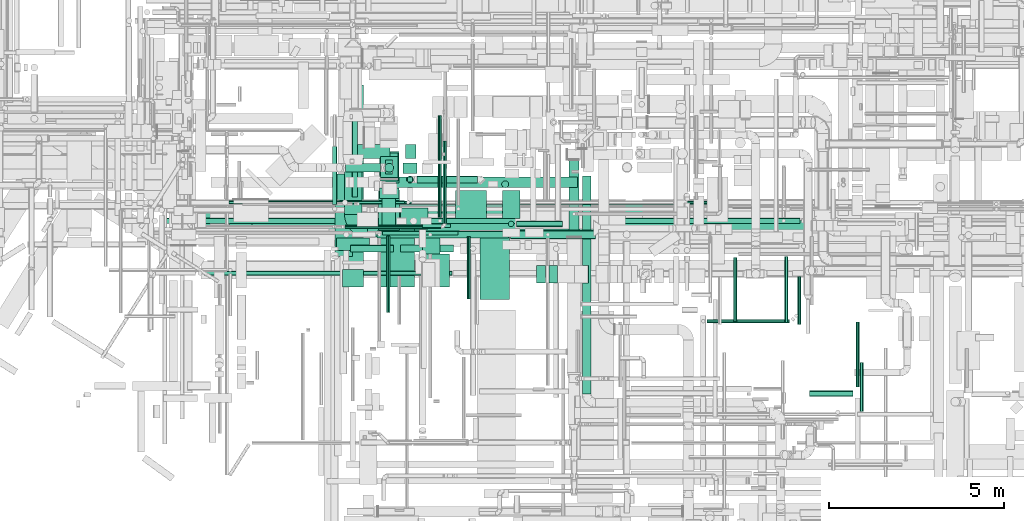
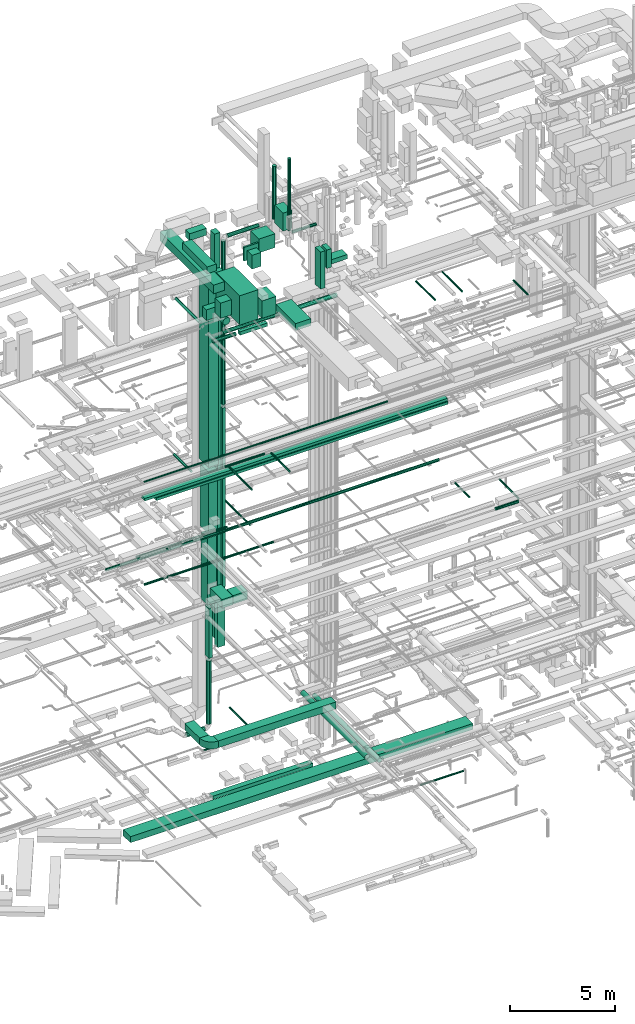
# One storey, part 31 of 337: 64 flow segments, 1 flow fitting.
"""IFC2X3 building model written with IfcOpenShell, lengths in millimetres."""

from ifc_helpers import new_model, entity, si_unit, converted_unit, derived_unit, direction, frame, frame_2d, origin, origin_2d_with_axis, place, context, subcontext, project, spatial, polyline, circle_curve, parameter, trimmed, segment, composite_curve, rectangle, circle, outline, extrude, source, transform, mapped, material, type_object, type_shapes, element, save


model = new_model("IFC2X3")

# Units and contexts
model_context = context("Model", 3, precision=0.01, world=origin(), true_north=direction((6.12303176911189e-17, 1.0)))
body_context = subcontext(model_context, "Body", "Model", "MODEL_VIEW")
ifc_project = project(units=[si_unit("LENGTHUNIT", "METRE", prefix="MILLI"), si_unit("AREAUNIT", "SQUARE_METRE"), si_unit("VOLUMEUNIT", "CUBIC_METRE"), converted_unit("PLANEANGLEUNIT", "DEGREE", entity("IfcRatioMeasure", 0.0174532925199433), si_unit("PLANEANGLEUNIT", "RADIAN"), dimensions=[0, 0, 0, 0, 0, 0, 0]), si_unit("MASSUNIT", "GRAM", prefix="KILO"), derived_unit("MASSDENSITYUNIT", [(si_unit("MASSUNIT", "GRAM", prefix="KILO"), 1), (si_unit("LENGTHUNIT", "METRE"), -3)]), derived_unit("MOMENTOFINERTIAUNIT", [(si_unit("LENGTHUNIT", "METRE"), 4)]), si_unit("TIMEUNIT", "SECOND"), si_unit("FREQUENCYUNIT", "HERTZ"), si_unit("THERMODYNAMICTEMPERATUREUNIT", "DEGREE_CELSIUS"), derived_unit("THERMALTRANSMITTANCEUNIT", [(si_unit("MASSUNIT", "GRAM", prefix="KILO"), 1), (si_unit("THERMODYNAMICTEMPERATUREUNIT", "KELVIN"), -1), (si_unit("TIMEUNIT", "SECOND"), -3)]), derived_unit("VOLUMETRICFLOWRATEUNIT", [(si_unit("LENGTHUNIT", "METRE"), 3), (si_unit("TIMEUNIT", "SECOND"), -1)]), derived_unit("MASSFLOWRATEUNIT", [(si_unit("MASSUNIT", "GRAM", prefix="KILO"), 1), (si_unit("TIMEUNIT", "SECOND"), -1)]), derived_unit("ROTATIONALFREQUENCYUNIT", [(si_unit("TIMEUNIT", "SECOND"), -1)]), si_unit("ELECTRICCURRENTUNIT", "AMPERE"), si_unit("ELECTRICVOLTAGEUNIT", "VOLT"), si_unit("POWERUNIT", "WATT"), si_unit("FORCEUNIT", "NEWTON", prefix="KILO"), si_unit("ILLUMINANCEUNIT", "LUX"), si_unit("LUMINOUSFLUXUNIT", "LUMEN"), si_unit("LUMINOUSINTENSITYUNIT", "CANDELA"), derived_unit("USERDEFINED", [(si_unit("MASSUNIT", "GRAM", prefix="KILO"), -1), (si_unit("LENGTHUNIT", "METRE"), -2), (si_unit("TIMEUNIT", "SECOND"), 3), (si_unit("LUMINOUSFLUXUNIT", "LUMEN"), 1)]), derived_unit("LINEARVELOCITYUNIT", [(si_unit("LENGTHUNIT", "METRE"), 1), (si_unit("TIMEUNIT", "SECOND"), -1)]), si_unit("PRESSUREUNIT", "PASCAL"), derived_unit("USERDEFINED", [(si_unit("LENGTHUNIT", "METRE"), -2), (si_unit("MASSUNIT", "GRAM", prefix="KILO"), 1), (si_unit("TIMEUNIT", "SECOND"), -2)]), derived_unit("LINEARFORCEUNIT", [(si_unit("MASSUNIT", "GRAM", prefix="KILO"), 1), (si_unit("LENGTHUNIT", "METRE"), 1), (si_unit("TIMEUNIT", "SECOND"), -2), (si_unit("LENGTHUNIT", "METRE"), -1)]), derived_unit("PLANARFORCEUNIT", [(si_unit("MASSUNIT", "GRAM", prefix="KILO"), 1), (si_unit("LENGTHUNIT", "METRE"), 1), (si_unit("TIMEUNIT", "SECOND"), -2), (si_unit("LENGTHUNIT", "METRE"), -2)])], contexts=[model_context])

# Site, building, storey
site_placement = place(None, origin())
site = spatial("IfcSite", under=ifc_project, at=site_placement, CompositionType="ELEMENT")
building_placement = place(site_placement, origin())
building = spatial("IfcBuilding", under=site, at=building_placement, CompositionType="ELEMENT")
storey_placement = place(building_placement, origin())
storey = spatial("IfcBuildingStorey", under=building, at=storey_placement, CompositionType="ELEMENT", Elevation=0.0)

# Flow segments
duct_segment_type_1 = type_object("IfcDuctSegmentType", PredefinedType="NOTDEFINED")
flow_segment_1_placement = place(storey_placement, frame((19019.38, 9470.01, -800.0)))
element("IfcFlowSegment", 1, at=flow_segment_1_placement, inside=storey, type_object=duct_segment_type_1, context=body_context, shape_type="SweptSolid", body=[
    extrude(rectangle(XDim=18790.1284833971, YDim=700.0, at=origin_2d_with_axis()), frame((9395.06, 350.0, 0.0)), (0.0, 0.0, 1.0), 350.0),
])
flow_segment_2_placement = place(storey_placement, frame((24662.3, 9490.54, 11050.0)))
element("IfcFlowSegment", 2, at=flow_segment_2_placement, inside=storey, type_object=duct_segment_type_1, context=body_context, shape_type="SweptSolid", body=[
    extrude(rectangle(XDim=795.000000000274, YDim=600.000000000001, at=origin_2d_with_axis()), frame((397.5, 300.0, 0.0), z_axis=(0.0, 0.0, 1.0), x_axis=(-1.0, 0.0, 0.0)), (0.0, 0.0, 1.0), 499.999999999999),
])
flow_segment_3_placement = place(storey_placement, frame((23065.55, 9899.08, 3200.0)))
element("IfcFlowSegment", 3, at=flow_segment_3_placement, inside=storey, type_object=duct_segment_type_1, context=body_context, shape_type="SweptSolid", body=[
    extrude(rectangle(XDim=1412.49999999996, YDim=499.999999999999, at=origin_2d_with_axis()), frame((250.0, 706.25, 0.0), z_axis=(0.0, 0.0, 1.0), x_axis=(0.0, 1.0, 0.0)), (0.0, 0.0, 1.0), 400.0),
])
flow_segment_4_placement = place(storey_placement, frame((23715.55, 9249.08, 3200.0)))
element("IfcFlowSegment", 4, at=flow_segment_4_placement, inside=storey, type_object=duct_segment_type_1, context=body_context, shape_type="SweptSolid", body=[
    extrude(rectangle(XDim=6460.00000000001, YDim=500.0, at=origin_2d_with_axis()), frame((3230.0, 250.0, 0.0)), (0.0, 0.0, 1.0), 400.0),
])
flow_segment_5_placement = place(storey_placement, frame((24092.29, 10849.36, 14489.99)))
element("IfcFlowSegment", 5, at=flow_segment_5_placement, inside=storey, type_object=duct_segment_type_1, context=body_context, shape_type="SweptSolid", body=[
    extrude(rectangle(XDim=499.999999999992, YDim=800.0, at=origin_2d_with_axis()), frame((250.0, 400.0, 0.01), z_axis=(3.9000782821359e-05, 0.0, 1.0), x_axis=(-1.0, 0.0, 3.9000782821359e-05)), (0.0, 0.0, 1.0), 3600.00000056566),
])
flow_segment_6_placement = place(storey_placement, frame((24242.3, 11049.36, 7100.0)))
element("IfcFlowSegment", 6, at=flow_segment_6_placement, inside=storey, type_object=duct_segment_type_1, context=body_context, shape_type="SweptSolid", body=[
    extrude(rectangle(XDim=400.0, YDim=199.999999999998, at=origin_2d_with_axis()), frame((100.0, 200.0, 0.0), z_axis=(0.0, 0.0, 1.0), x_axis=(0.0, 1.0, 0.0)), (0.0, 0.0, 1.0), 2910.00000000006),
])
flow_segment_7_placement = place(storey_placement, frame((24092.3, 10949.36, 10310.0)))
element("IfcFlowSegment", 7, at=flow_segment_7_placement, inside=storey, type_object=duct_segment_type_1, context=body_context, shape_type="SweptSolid", body=[
    extrude(rectangle(XDim=499.999999999999, YDim=600.0, at=origin_2d_with_axis()), frame((250.0, 300.0, 0.0), z_axis=(0.0, 0.0, 1.0), x_axis=(-1.0, 0.0, 0.0)), (0.0, 0.0, 1.0), 3880.00000000004),
])
flow_segment_8_placement = place(storey_placement, frame((24067.42, 10799.36, 18390.0)))
element("IfcFlowSegment", 8, at=flow_segment_8_placement, inside=storey, type_object=duct_segment_type_1, context=body_context, shape_type="SweptSolid", body=[
    extrude(rectangle(XDim=900.000000000001, YDim=549.999999999999, at=origin_2d_with_axis()), frame((275.01, 450.0, 0.0), z_axis=(-1.06206758286217e-06, 0.0, 1.0), x_axis=(0.0, 1.0, 0.0)), (0.0, 0.0, 1.0), 10469.9999552325),
])
flow_segment_9_placement = place(storey_placement, frame((19781.36, 9425.09, 18780.0)))
element("IfcFlowSegment", 9, at=flow_segment_9_placement, inside=storey, type_object=duct_segment_type_1, context=body_context, shape_type="SweptSolid", body=[
    extrude(rectangle(XDim=16609.7802616782, YDim=300.0, at=origin_2d_with_axis()), frame((8304.89, 150.0, 0.0), z_axis=(0.0, 0.0, 1.0), x_axis=(-1.0, 0.0, 0.0)), (0.0, 0.0, 1.0), 150.000000000001),
])
flow_segment_10_placement = place(storey_placement, frame((24042.3, 9460.54, 11050.0)))
element("IfcFlowSegment", 10, at=flow_segment_10_placement, inside=storey, type_object=duct_segment_type_1, context=body_context, shape_type="SweptSolid", body=[
    extrude(rectangle(XDim=1137.81651873405, YDim=600.000000000002, at=origin_2d_with_axis()), frame((300.0, 568.91, 0.0), z_axis=(0.0, 0.0, 1.0), x_axis=(0.0, 1.0, 0.0)), (0.0, 0.0, 1.0), 499.999999999999),
])
flow_segment_11_placement = place(storey_placement, frame((20420.04, 9425.61, 18580.0)))
element("IfcFlowSegment", 11, at=flow_segment_11_placement, inside=storey, type_object=duct_segment_type_1, context=body_context, shape_type="SweptSolid", body=[
    extrude(rectangle(XDim=16005.2921321211, YDim=300.0, at=origin_2d_with_axis()), frame((8002.65, 150.0, 0.0)), (0.0, 0.0, 1.0), 150.000000000001),
])
flow_segment_12_placement = place(storey_placement, frame((24671.92, 8824.98, 27050.0)))
element("IfcFlowSegment", 12, at=flow_segment_12_placement, inside=storey, type_object=duct_segment_type_1, context=body_context, shape_type="SweptSolid", body=[
    extrude(rectangle(XDim=1504.99999999992, YDim=200.0, at=origin_2d_with_axis()), frame((752.5, 100.0, 0.0), z_axis=(0.0, 0.0, 1.0), x_axis=(-1.0, 0.0, 0.0)), (0.0, 0.0, 1.0), 199.999999999998),
])
flow_segment_13_placement = place(storey_placement, frame((24808.28, 11498.95, 7800.0)))
element("IfcFlowSegment", 13, at=flow_segment_13_placement, inside=storey, type_object=duct_segment_type_1, context=body_context, shape_type="SweptSolid", body=[
    extrude(rectangle(XDim=300.000000000001, YDim=400.0, at=origin_2d_with_axis()), frame((150.0, 200.0, 0.0)), (0.0, 0.0, 1.0), 23450.0000000001),
])
flow_segment_14_placement = place(storey_placement, frame((24733.23, 11074.99, 7550.0)))
element("IfcFlowSegment", 14, at=flow_segment_14_placement, inside=storey, type_object=duct_segment_type_1, context=body_context, shape_type="SweptSolid", body=[
    extrude(rectangle(XDim=300.000000000001, YDim=400.0, at=origin_2d_with_axis()), frame((200.0, 150.0, 0.0), z_axis=(0.0, 0.0, 1.0), x_axis=(0.0, -1.0, 0.0)), (0.0, 0.0, 1.0), 20899.9997394166),
])
flow_segment_15_placement = place(storey_placement, frame((26930.62, 7474.06, 27350.0)))
element("IfcFlowSegment", 15, at=flow_segment_15_placement, inside=storey, type_object=duct_segment_type_1, context=body_context, shape_type="SweptSolid", body=[
    extrude(rectangle(XDim=1865.90580735633, YDim=850.000000000002, at=origin_2d_with_axis()), frame((425.0, 932.95, 0.0), z_axis=(0.0, 0.0, 1.0), x_axis=(0.0, 1.0, 0.0)), (0.0, 0.0, 1.0), 399.999999999996),
])
flow_segment_16_placement = place(storey_placement, frame((22842.03, 8872.6, 28512.0)))
element("IfcFlowSegment", 16, at=flow_segment_16_placement, inside=storey, type_object=duct_segment_type_1, context=body_context, shape_type="SweptSolid", body=[
    extrude(rectangle(XDim=357.000000000056, YDim=939.999999999999, at=origin_2d_with_axis()), frame((470.0, 178.5, 0.0), z_axis=(0.0, 0.0, 1.0), x_axis=(0.0, -1.0, 0.0)), (0.0, 0.0, 1.0), 619.999999999998),
])
flow_segment_17_placement = place(storey_placement, frame((24861.21, 10822.55, 11150.0)))
element("IfcFlowSegment", 17, at=flow_segment_17_placement, inside=storey, type_object=duct_segment_type_1, context=body_context, shape_type="SweptSolid", body=[
    extrude(rectangle(XDim=150.000000000001, YDim=150.000000000001, at=origin_2d_with_axis()), frame((75.0, 75.0, 0.0), z_axis=(0.0, 0.0, 1.0), x_axis=(0.0, 1.0, 0.0)), (0.0, 0.0, 1.0), 10392.0),
])
flow_segment_18_placement = place(storey_placement, frame((24231.5, 10670.0, -850.0)))
element("IfcFlowSegment", 18, at=flow_segment_18_placement, inside=storey, type_object=duct_segment_type_1, context=body_context, shape_type="SweptSolid", body=[
    extrude(rectangle(XDim=5495.94816144537, YDim=299.999999999999, at=origin_2d_with_axis()), frame((2747.97, 150.0, 0.0), z_axis=(0.0, 0.0, 1.0), x_axis=(-1.0, 0.0, 0.0)), (0.0, 0.0, 1.0), 200.0),
])
duct_segment_type_2 = type_object("IfcDuctSegmentType", PredefinedType="NOTDEFINED")
flow_segment_19_placement = place(storey_placement, frame((33418.35, 6797.92, -951.6)))
element("IfcFlowSegment", 19, at=flow_segment_19_placement, inside=storey, type_object=duct_segment_type_2, context=body_context, shape_type="SweptSolid", body=[
    extrude(circle(Radius=50.0, at=origin_2d_with_axis()), frame((0.0, 51.6, 51.6), z_axis=(1.0, 0.0, 0.0), x_axis=(0.0, -1.0, 0.0)), (0.0, 0.0, 1.0), 2362.95263376269),
])
flow_segment_20_placement = place(storey_placement, frame((23095.67, 11107.76, 2843.4)))
element("IfcFlowSegment", 20, at=flow_segment_20_placement, inside=storey, type_object=duct_segment_type_2, context=body_context, shape_type="SweptSolid", body=[
    extrude(circle(Radius=125.0, at=origin_2d_with_axis()), frame((0.0, 126.6, 126.6), z_axis=(1.0, 0.0, 0.0), x_axis=(0.0, -1.0, 0.0)), (0.0, 0.0, 1.0), 996.624916994883),
])
flow_segment_21_placement = place(storey_placement, frame((23084.87, 9491.98, 3048.4)))
element("IfcFlowSegment", 21, at=flow_segment_21_placement, inside=storey, type_object=duct_segment_type_2, context=body_context, shape_type="SweptSolid", body=[
    extrude(circle(Radius=50.0, at=origin_2d_with_axis()), frame((0.0, 51.6, 51.6), z_axis=(1.0, 0.0, 0.0), x_axis=(0.0, 1.0, 0.0)), (0.0, 0.0, 1.0), 2738.57864376277),
])
flow_segment_22_placement = place(storey_placement, frame((25871.85, 9643.58, 3048.4)))
element("IfcFlowSegment", 22, at=flow_segment_22_placement, inside=storey, type_object=duct_segment_type_2, context=body_context, shape_type="SweptSolid", body=[
    extrude(circle(Radius=50.0, at=origin_2d_with_axis()), frame((51.6, 0.0, 51.6), z_axis=(0.0, 1.0, 0.0), x_axis=(1.0, 0.0, 0.0)), (0.0, 0.0, 1.0), 2359.99999999999),
])
flow_segment_23_placement = place(storey_placement, frame((29864.42, 4770.47, 2873.4)))
element("IfcFlowSegment", 23, at=flow_segment_23_placement, inside=storey, type_object=duct_segment_type_2, context=body_context, shape_type="SweptSolid", body=[
    extrude(circle(Radius=125.0, at=origin_2d_with_axis()), frame((126.6, 0.0, 126.6), z_axis=(0.0, 1.0, 0.0), x_axis=(-1.0, 0.0, 0.0)), (0.0, 0.0, 1.0), 6224.02842229614),
])
flow_segment_24_placement = place(storey_placement, frame((22718.49, 10182.12, 18920.9)))
element("IfcFlowSegment", 24, at=flow_segment_24_placement, inside=storey, type_object=duct_segment_type_2, context=body_context, shape_type="SweptSolid", body=[
    extrude(circle(Radius=62.5, at=origin_2d_with_axis()), frame((64.1, 0.0, 64.1), z_axis=(0.0, 1.0, 0.0), x_axis=(1.0, 0.0, 0.0)), (0.0, 0.0, 1.0), 1655.00000000002),
])
flow_segment_25_placement = place(storey_placement, frame((24215.7, 11107.76, 3220.0)))
element("IfcFlowSegment", 25, at=flow_segment_25_placement, inside=storey, type_object=duct_segment_type_2, context=body_context, shape_type="SweptSolid", body=[
    extrude(circle(Radius=125.0, at=origin_2d_with_axis()), frame((126.6, 126.6, 0.0), z_axis=(0.0, 0.0, 1.0), x_axis=(0.0, -1.0, 0.0)), (0.0, 0.0, 1.0), 3680.00000000007),
])
flow_segment_26_placement = place(storey_placement, frame((20219.89, 10185.8, 19198.4)))
element("IfcFlowSegment", 26, at=flow_segment_26_placement, inside=storey, type_object=duct_segment_type_2, context=body_context, shape_type="SweptSolid", body=[
    extrude(circle(Radius=50.0, at=origin_2d_with_axis()), frame((0.0, 51.6, 51.6), z_axis=(1.0, 0.0, 0.0), x_axis=(0.0, 1.0, 0.0)), (0.0, 0.0, 1.0), 13355.0),
])
flow_segment_27_placement = place(storey_placement, frame((26568.45, 7489.39, 19223.4)))
element("IfcFlowSegment", 27, at=flow_segment_27_placement, inside=storey, type_object=duct_segment_type_2, context=body_context, shape_type="SweptSolid", body=[
    extrude(circle(Radius=50.0, at=origin_2d_with_axis()), frame((51.6, 0.0, 51.6), z_axis=(0.0, 1.0, 0.0), x_axis=(-1.0, 0.0, 0.0)), (0.0, 0.0, 1.0), 1780.73265127521),
])
flow_segment_28_placement = place(storey_placement, frame((24149.84, 9306.02, 19210.9)))
element("IfcFlowSegment", 28, at=flow_segment_28_placement, inside=storey, type_object=duct_segment_type_2, context=body_context, shape_type="SweptSolid", body=[
    extrude(circle(Radius=62.5, at=origin_2d_with_axis()), frame((0.0, 64.1, 64.1), z_axis=(1.0, 0.0, 0.0), x_axis=(0.0, 1.0, 0.0)), (0.0, 0.0, 1.0), 2164.99999999999),
])
flow_segment_29_placement = place(storey_placement, frame((37677.16, 4972.09, 15298.4)))
element("IfcFlowSegment", 29, at=flow_segment_29_placement, inside=storey, type_object=duct_segment_type_2, context=body_context, shape_type="SweptSolid", body=[
    extrude(circle(Radius=50.0, at=origin_2d_with_axis()), frame((51.6, 0.0, 51.6), z_axis=(0.0, 1.0, 0.0), x_axis=(1.0, 0.0, 0.0)), (0.0, 0.0, 1.0), 1858.35190000008),
])
flow_segment_30_placement = place(storey_placement, frame((36348.75, 4700.5, 15268.4)))
element("IfcFlowSegment", 30, at=flow_segment_30_placement, inside=storey, type_object=duct_segment_type_2, context=body_context, shape_type="SweptSolid", body=[
    extrude(circle(Radius=80.0, at=origin_2d_with_axis()), frame((0.0, 81.6, 81.6), z_axis=(1.0, 0.0, 0.0), x_axis=(0.0, 1.0, 0.0)), (0.0, 0.0, 1.0), 1249.99999973248),
])
flow_segment_31_placement = place(storey_placement, frame((25739.15, 9815.69, 14998.4)))
element("IfcFlowSegment", 31, at=flow_segment_31_placement, inside=storey, type_object=duct_segment_type_2, context=body_context, shape_type="SweptSolid", body=[
    extrude(circle(Radius=50.0, at=origin_2d_with_axis()), frame((51.6, 0.0, 51.6), z_axis=(0.0, 1.0, 0.0), x_axis=(-1.0, 0.0, 0.0)), (0.0, 0.0, 1.0), 2918.62778646186),
])
flow_segment_32_placement = place(storey_placement, frame((17807.22, 9634.09, 15218.4)))
element("IfcFlowSegment", 32, at=flow_segment_32_placement, inside=storey, type_object=duct_segment_type_2, context=body_context, shape_type="SweptSolid", body=[
    extrude(circle(Radius=80.0, at=origin_2d_with_axis()), frame((0.0, 81.6, 81.6), z_axis=(1.0, 0.0, 0.0), x_axis=(0.0, 1.0, 0.0)), (0.0, 0.0, 1.0), 18280.0),
])
flow_segment_33_placement = place(storey_placement, frame((36015.06, 6759.63, 14873.4)))
element("IfcFlowSegment", 33, at=flow_segment_33_placement, inside=storey, type_object=duct_segment_type_2, context=body_context, shape_type="SweptSolid", body=[
    extrude(circle(Radius=50.0, at=origin_2d_with_axis()), frame((51.6, 0.0, 51.6), z_axis=(0.0, 1.0, 0.0), x_axis=(-1.0, 0.0, 0.0)), (0.0, 0.0, 1.0), 1365.00000000021),
])
flow_segment_34_placement = place(storey_placement, frame((19060.56, 8155.54, 14860.9)))
element("IfcFlowSegment", 34, at=flow_segment_34_placement, inside=storey, type_object=duct_segment_type_2, context=body_context, shape_type="SweptSolid", body=[
    extrude(circle(Radius=62.5, at=origin_2d_with_axis()), frame((0.0, 64.1, 64.1), z_axis=(1.0, 0.0, 0.0), x_axis=(0.0, 1.0, 0.0)), (0.0, 0.0, 1.0), 7075.00000000001),
])
flow_segment_35_placement = place(storey_placement, frame((19770.03, 10194.7, 14998.4)))
element("IfcFlowSegment", 35, at=flow_segment_35_placement, inside=storey, type_object=duct_segment_type_2, context=body_context, shape_type="SweptSolid", body=[
    extrude(circle(Radius=50.0, at=origin_2d_with_axis()), frame((0.0, 51.6, 51.6), z_axis=(1.0, 0.0, 0.0), x_axis=(0.0, 1.0, 0.0)), (0.0, 0.0, 1.0), 5013.99999999999),
])
flow_segment_36_placement = place(storey_placement, frame((24127.7, 9529.36, 27358.4)))
element("IfcFlowSegment", 36, at=flow_segment_36_placement, inside=storey, type_object=duct_segment_type_2, context=body_context, shape_type="SweptSolid", body=[
    extrude(circle(Radius=200.0, at=origin_2d_with_axis()), frame((201.6, 0.0, 201.6), z_axis=(0.0, 1.0, 0.0), x_axis=(-1.0, 0.0, 0.0)), (0.0, 0.0, 1.0), 1250.0),
])
flow_segment_37_placement = place(storey_placement, frame((23280.83, 10393.8, 27238.4)))
element("IfcFlowSegment", 37, at=flow_segment_37_placement, inside=storey, type_object=duct_segment_type_2, context=body_context, shape_type="SweptSolid", body=[
    extrude(circle(Radius=80.0, at=origin_2d_with_axis()), frame((81.6, 0.0, 81.6), z_axis=(0.0, 1.0, 0.0), x_axis=(1.0, 0.0, 0.0)), (0.0, 0.0, 1.0), 2259.09981458927),
])
flow_segment_38_placement = place(storey_placement, frame((23233.85, 8823.38, 27048.4)))
element("IfcFlowSegment", 38, at=flow_segment_38_placement, inside=storey, type_object=duct_segment_type_2, context=body_context, shape_type="SweptSolid", body=[
    extrude(circle(Radius=100.0, at=origin_2d_with_axis()), frame((0.0, 101.6, 101.6), z_axis=(1.0, 0.0, 0.0), x_axis=(0.0, 1.0, 0.0)), (0.0, 0.0, 1.0), 1238.07191838703),
])
flow_segment_39_placement = place(storey_placement, frame((37794.79, 4269.71, 27498.4)))
element("IfcFlowSegment", 39, at=flow_segment_39_placement, inside=storey, type_object=duct_segment_type_2, context=body_context, shape_type="SweptSolid", body=[
    extrude(circle(Radius=50.0, at=origin_2d_with_axis()), frame((51.6, 0.0, 51.6), z_axis=(0.0, 1.0, 0.0), x_axis=(1.0, 0.0, 0.0)), (0.0, 0.0, 1.0), 1399.99999999991),
])
flow_segment_40_placement = place(storey_placement, frame((27803.85, 9197.81, 27023.4)))
element("IfcFlowSegment", 40, at=flow_segment_40_placement, inside=storey, type_object=duct_segment_type_2, context=body_context, shape_type="SweptSolid", body=[
    extrude(circle(Radius=125.0, at=origin_2d_with_axis()), frame((0.0, 126.6, 126.6), z_axis=(1.0, 0.0, 0.0), x_axis=(0.0, 1.0, 0.0)), (0.0, 0.0, 1.0), 2430.0),
])
flow_segment_41_placement = place(storey_placement, frame((23993.85, 9222.81, 27048.4)))
element("IfcFlowSegment", 41, at=flow_segment_41_placement, inside=storey, type_object=duct_segment_type_2, context=body_context, shape_type="SweptSolid", body=[
    extrude(circle(Radius=100.0, at=origin_2d_with_axis()), frame((0.0, 101.6, 101.6), z_axis=(1.0, 0.0, 0.0), x_axis=(0.0, 1.0, 0.0)), (0.0, 0.0, 1.0), 3759.99999999999),
])
flow_segment_42_placement = place(storey_placement, frame((24269.27, 7098.58, 19223.4)))
element("IfcFlowSegment", 42, at=flow_segment_42_placement, inside=storey, type_object=duct_segment_type_2, context=body_context, shape_type="SweptSolid", body=[
    extrude(circle(Radius=50.0, at=origin_2d_with_axis()), frame((51.6, 0.0, 51.6), z_axis=(0.0, 1.0, 0.0), x_axis=(-1.0, 0.0, 0.0)), (0.0, 0.0, 1.0), 2189.0373331274),
])
flow_segment_43_placement = place(storey_placement, frame((34174.08, 6844.63, 26898.4)))
element("IfcFlowSegment", 43, at=flow_segment_43_placement, inside=storey, type_object=duct_segment_type_2, context=body_context, shape_type="SweptSolid", body=[
    extrude(circle(Radius=50.0, at=origin_2d_with_axis()), frame((51.6, 0.0, 51.6), z_axis=(0.0, 1.0, 0.0), x_axis=(-1.0, 0.0, 0.0)), (0.0, 0.0, 1.0), 1819.99999999997),
])
flow_segment_44_placement = place(storey_placement, frame((35639.61, 6814.63, 26898.4)))
element("IfcFlowSegment", 44, at=flow_segment_44_placement, inside=storey, type_object=duct_segment_type_2, context=body_context, shape_type="SweptSolid", body=[
    extrude(circle(Radius=50.0, at=origin_2d_with_axis()), frame((51.6, 0.0, 51.6), z_axis=(0.0, 1.0, 0.0), x_axis=(-1.0, 0.0, 0.0)), (0.0, 0.0, 1.0), 1879.99999999998),
])
flow_segment_45_placement = place(storey_placement, frame((27984.64, 9546.24, 31323.41)))
element("IfcFlowSegment", 45, at=flow_segment_45_placement, inside=storey, type_object=duct_segment_type_2, context=body_context, shape_type="SweptSolid", body=[
    extrude(circle(Radius=80.0, at=origin_2d_with_axis()), frame((0.0, 81.6, 81.6), z_axis=(1.0, 0.0, 0.0), x_axis=(0.0, -1.0, 0.0)), (0.0, 0.0, 1.0), 1310.00000000001),
])
flow_segment_46_placement = place(storey_placement, frame((29482.65, 5324.34, 2858.4)))
element("IfcFlowSegment", 46, at=flow_segment_46_placement, inside=storey, type_object=duct_segment_type_2, context=body_context, shape_type="SweptSolid", body=[
    extrude(circle(Radius=140.0, at=origin_2d_with_axis()), frame((141.6, 0.0, 141.6), z_axis=(0.0, 1.0, 0.0), x_axis=(1.0, 0.0, 0.0)), (0.0, 0.0, 1.0), 6120.61737587125),
])
flow_segment_47_placement = place(storey_placement, frame((27743.04, 9546.24, 31565.01)))
element("IfcFlowSegment", 47, at=flow_segment_47_placement, inside=storey, type_object=duct_segment_type_2, context=body_context, shape_type="SweptSolid", body=[
    extrude(circle(Radius=80.0, at=origin_2d_with_axis()), frame((81.6, 81.6, 0.0), z_axis=(0.0, 0.0, 1.0), x_axis=(0.0, 1.0, 0.0)), (0.0, 0.0, 1.0), 4174.99231480953),
])
flow_segment_48_placement = place(storey_placement, frame((24834.62, 10795.96, 21742.0)))
element("IfcFlowSegment", 48, at=flow_segment_48_placement, inside=storey, type_object=duct_segment_type_2, context=body_context, shape_type="SweptSolid", body=[
    extrude(circle(Radius=100.0, at=origin_2d_with_axis()), frame((101.6, 101.6, 0.0), z_axis=(0.0, 0.0, 1.0), x_axis=(-1.0, 0.0, 0.0)), (0.0, 0.0, 1.0), 9468.10638854295),
])
flow_segment_49_placement = place(storey_placement, frame((25136.21, 10795.96, 31308.51)))
element("IfcFlowSegment", 49, at=flow_segment_49_placement, inside=storey, type_object=duct_segment_type_2, context=body_context, shape_type="SweptSolid", body=[
    extrude(circle(Radius=100.0, at=origin_2d_with_axis()), frame((0.0, 101.6, 101.6), z_axis=(1.0, 0.0, 0.0), x_axis=(0.0, -1.0, 0.0)), (0.0, 0.0, 1.0), 1726.29701289197),
])
flow_segment_50_placement = place(storey_placement, frame((27555.37, 10660.32, 31610.11)))
element("IfcFlowSegment", 50, at=flow_segment_50_placement, inside=storey, type_object=duct_segment_type_2, context=body_context, shape_type="SweptSolid", body=[
    extrude(circle(Radius=100.0, at=origin_2d_with_axis()), frame((101.6, 101.6, 0.0), z_axis=(0.0, 0.0, 1.0), x_axis=(0.0, -1.0, 0.0)), (0.0, 0.0, 1.0), 3079.89361145706),
])
duct_segment_type_3 = type_object("IfcDuctSegmentType", PredefinedType="NOTDEFINED")
flow_segment_51_placement = place(storey_placement, frame((27574.64, 9777.84, 31500.0)))
element("IfcFlowSegment", 51, at=flow_segment_51_placement, inside=storey, type_object=duct_segment_type_3, context=body_context, shape_type="SweptSolid", body=[
    extrude(rectangle(XDim=499.999999999999, YDim=800.0, at=origin_2d_with_axis()), frame((250.0, 400.0, 0.0)), (0.0, 0.0, 1.0), 1040.00000000007),
])
flow_segment_52_placement = place(storey_placement, frame((26240.29, 9777.84, 30700.0)))
element("IfcFlowSegment", 52, at=flow_segment_52_placement, inside=storey, type_object=duct_segment_type_3, context=body_context, shape_type="SweptSolid", body=[
    extrude(rectangle(XDim=884.346249999947, YDim=800.0, at=origin_2d_with_axis()), frame((442.17, 400.0, 0.0)), (0.0, 0.0, 1.0), 800.0),
])
flow_segment_53_placement = place(storey_placement, frame((25290.29, 9530.98, 30700.0)))
element("IfcFlowSegment", 53, at=flow_segment_53_placement, inside=storey, type_object=duct_segment_type_3, context=body_context, shape_type="SweptSolid", body=[
    extrude(rectangle(XDim=96.8584847521986, YDim=800.0, at=origin_2d_with_axis()), frame((400.0, 48.43, 0.0), z_axis=(0.0, 0.0, 1.0), x_axis=(0.0, -1.0, 0.0)), (0.0, 0.0, 1.0), 800.0),
])
flow_segment_54_placement = place(storey_placement, frame((25290.29, 8774.6, 30700.0)))
element("IfcFlowSegment", 54, at=flow_segment_54_placement, inside=storey, type_object=duct_segment_type_3, context=body_context, shape_type="SweptSolid", body=[
    extrude(rectangle(XDim=456.377020250045, YDim=499.999999999999, at=origin_2d_with_axis()), frame((250.0, 228.19, 0.0), z_axis=(0.0, 0.0, 1.0), x_axis=(0.0, -1.0, 0.0)), (0.0, 0.0, 1.0), 800.0),
])
flow_segment_55_placement = place(storey_placement, frame((25289.29, 7824.6, 28425.0)))
element("IfcFlowSegment", 55, at=flow_segment_55_placement, inside=storey, type_object=duct_segment_type_3, context=body_context, shape_type="SweptSolid", body=[
    extrude(rectangle(XDim=950.000000000008, YDim=780.0, at=origin_2d_with_axis()), frame((390.0, 475.0, 0.0), z_axis=(0.0, 0.0, 1.0), x_axis=(0.0, -1.0, 0.0)), (0.0, 0.0, 1.0), 999.999999999998),
])
flow_segment_56_placement = place(storey_placement, frame((24067.42, 10356.6, 29010.0)))
element("IfcFlowSegment", 56, at=flow_segment_56_placement, inside=storey, type_object=duct_segment_type_3, context=body_context, shape_type="SweptSolid", body=[
    extrude(rectangle(XDim=292.755701990598, YDim=550.000000000001, at=origin_2d_with_axis()), frame((275.0, 146.38, 0.0), z_axis=(0.0, 0.0, 1.0), x_axis=(0.0, 1.0, 0.0)), (0.0, 0.0, 1.0), 900.000000000003),
])
flow_segment_57_placement = place(storey_placement, frame((24067.42, 7824.6, 28460.0)))
element("IfcFlowSegment", 57, at=flow_segment_57_placement, inside=storey, type_object=duct_segment_type_3, context=body_context, shape_type="SweptSolid", body=[
    extrude(rectangle(XDim=2232.00000000001, YDim=1000.0, at=origin_2d_with_axis()), frame((500.0, 1116.0, 0.0), z_axis=(0.0, 0.0, 1.0), x_axis=(0.0, 1.0, 0.0)), (0.0, 0.0, 1.0), 1700.0),
])
flow_segment_58_placement = place(storey_placement, frame((23012.03, 8476.61, 30250.0)))
element("IfcFlowSegment", 58, at=flow_segment_58_placement, inside=storey, type_object=duct_segment_type_3, context=body_context, shape_type="SweptSolid", body=[
    extrude(rectangle(XDim=5116.12485000001, YDim=599.999999999998, at=origin_2d_with_axis()), frame((300.0, 2558.06, 0.0), z_axis=(0.0, 0.0, 1.0), x_axis=(0.0, 1.0, 0.0)), (0.0, 0.0, 1.0), 499.999999999999),
])
flow_segment_59_placement = place(storey_placement, frame((23012.03, 7826.61, 29222.0)))
element("IfcFlowSegment", 59, at=flow_segment_59_placement, inside=storey, type_object=duct_segment_type_3, context=body_context, shape_type="SweptSolid", body=[
    extrude(rectangle(XDim=499.999999999998, YDim=599.999999999998, at=origin_2d_with_axis()), frame((300.0, 250.0, 0.0), z_axis=(0.0, 0.0, 1.0), x_axis=(0.0, -1.0, 0.0)), (0.0, 0.0, 1.0), 877.999975000453),
])
flow_segment_60_placement = place(storey_placement, frame((22790.03, 8699.6, 31350.0)))
element("IfcFlowSegment", 60, at=flow_segment_60_placement, inside=storey, type_object=duct_segment_type_3, context=body_context, shape_type="SweptSolid", body=[
    extrude(rectangle(XDim=2349.34341489102, YDim=499.999999999999, at=origin_2d_with_axis()), frame((250.0, 1174.67, 0.0), z_axis=(0.0, 0.0, 1.0), x_axis=(0.0, 1.0, 0.0)), (0.0, 0.0, 1.0), 399.999999999996),
])
flow_segment_61_placement = place(storey_placement, frame((23440.03, 11498.95, 31350.0)))
element("IfcFlowSegment", 61, at=flow_segment_61_placement, inside=storey, type_object=duct_segment_type_3, context=body_context, shape_type="SweptSolid", body=[
    extrude(rectangle(XDim=918.250744999949, YDim=400.0, at=origin_2d_with_axis()), frame((459.13, 200.0, 0.0)), (0.0, 0.0, 1.0), 400.000000000004),
])
flow_segment_62_placement = place(storey_placement, frame((28905.0, 7934.5, 29975.0)))
element("IfcFlowSegment", 62, at=flow_segment_62_placement, inside=storey, type_object=duct_segment_type_3, context=body_context, shape_type="SweptSolid", body=[
    extrude(rectangle(XDim=250.000000000004, YDim=500.0, at=origin_2d_with_axis()), frame((125.0, 250.0, 0.0)), (0.0, 0.0, 1.0), 1074.99995000004),
])
flow_segment_63_placement = place(storey_placement, frame((28555.03, 7934.5, 28900.0)))
element("IfcFlowSegment", 63, at=flow_segment_63_placement, inside=storey, type_object=duct_segment_type_3, context=body_context, shape_type="SweptSolid", body=[
    extrude(rectangle(XDim=500.000000000001, YDim=249.999999999999, at=origin_2d_with_axis()), frame((125.0, 250.0, 0.0), z_axis=(0.0, 0.0, 1.0), x_axis=(0.0, 1.0, 0.0)), (0.0, 0.0, 1.0), 2149.99997500004),
])
flow_segment_64_placement = place(storey_placement, frame((29175.0, 7934.5, 30150.0)))
element("IfcFlowSegment", 64, at=flow_segment_64_placement, inside=storey, type_object=duct_segment_type_3, context=body_context, shape_type="SweptSolid", body=[
    extrude(rectangle(XDim=858.063968837481, YDim=500.0, at=origin_2d_with_axis()), frame((429.03, 250.0, 0.0)), (0.0, 0.0, 1.0), 250.000000000004),
])

# Flow fitting
ifc_material = material()
duct_fitting_type = type_object("IfcDuctFittingType", PredefinedType="NOTDEFINED", material=ifc_material)
shared_shape = source(origin(), body_context, "Body", "SweptSolid", [
    extrude(outline(composite_curve([segment(polyline([(-450.0, -200.0), (50.0, -200.0)]), True, "CONTINUOUS"), segment(trimmed(circle_curve(frame_2d((200.0, -200.0), x_axis=(0.0, 1.0)), 150.0), [parameter(0.0)], [parameter(90.0000000000001)], True, "PARAMETER"), False, "CONTINUOUS"), segment(polyline([(200.0, -50.0), (200.0, 450.0)]), True, "CONTINUOUS"), segment(trimmed(circle_curve(frame_2d((200.0, -200.0), x_axis=(0.0, 1.0)), 650.0), [parameter(0.0)], [parameter(90.0000000000001)], True, "PARAMETER"), True, "CONTINUOUS")], self_intersect=False)), frame((-200.0, 200.0, -200.0), z_axis=(0.0, 0.0, 1.0), x_axis=(-1.0, 0.0, 0.0)), (0.0, 0.0, 1.0), 400.0),
])
type_shapes(duct_fitting_type, [shared_shape])
flow_fitting_placement = place(storey_placement, frame((23315.55, 9499.08, 3400.0), z_axis=(0.0, 0.0, 1.0), x_axis=(0.0, -1.0, 0.0)))
element("IfcFlowFitting", 65, at=flow_fitting_placement, inside=storey, type_object=duct_fitting_type, material=ifc_material, context=body_context, shape_type="MappedRepresentation", body=[
    mapped(shared_shape, transform((0.0, 0.0, 0.0), scale=1.0)),
])

save(model, "model.ifc")
